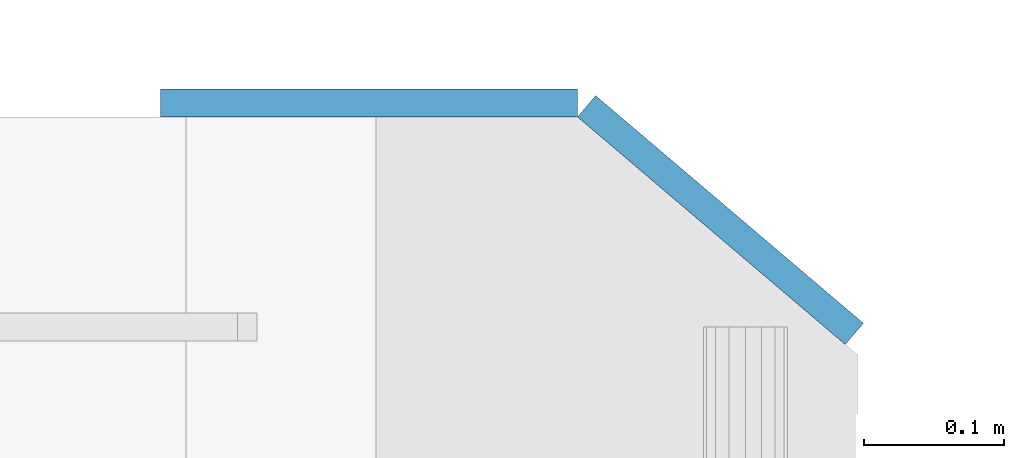
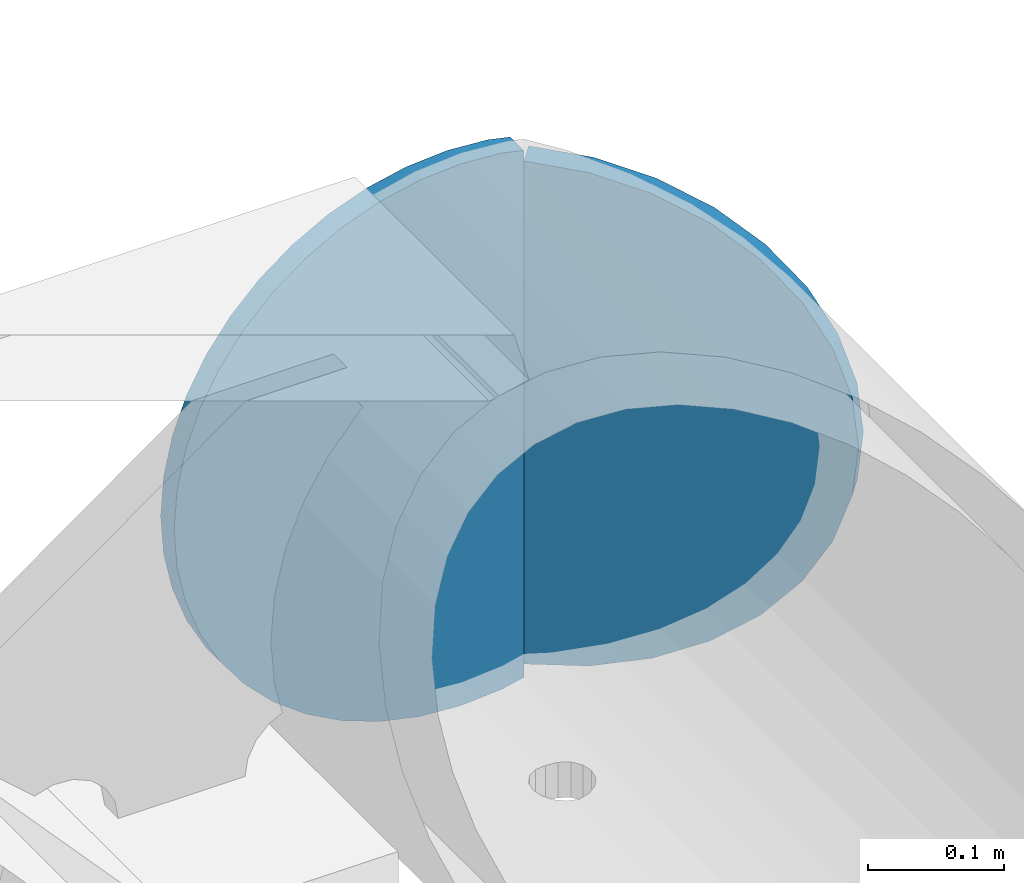
# One storey, part 207 of 219: 2 plates.
"""IFC2X3 building model written with IfcOpenShell, lengths in millimetres."""

from ifc_helpers import new_model, si_unit, frame, origin_with_axes, place, context, subcontext, project, spatial, faceted_brep, material, type_object, element, save


model = new_model("IFC2X3")

# Units and contexts
model_context = context("Model", 3, precision=1e-05, world=origin_with_axes())
body_context = subcontext(model_context, "Body", "Model", "MODEL_VIEW")
ifc_project = project(units=[si_unit("LENGTHUNIT", "METRE", prefix="MILLI"), si_unit("AREAUNIT", "SQUARE_METRE"), si_unit("VOLUMEUNIT", "CUBIC_METRE"), si_unit("MASSUNIT", "GRAM", prefix="KILO"), si_unit("TIMEUNIT", "SECOND"), si_unit("PLANEANGLEUNIT", "RADIAN"), si_unit("SOLIDANGLEUNIT", "STERADIAN"), si_unit("THERMODYNAMICTEMPERATUREUNIT", "DEGREE_CELSIUS"), si_unit("LUMINOUSINTENSITYUNIT", "LUMEN")], contexts=[model_context])

# Site, building, storey
site_placement = place(None, origin_with_axes())
site = spatial("IfcSite", under=ifc_project, at=site_placement, CompositionType="ELEMENT")
building_placement = place(site_placement, origin_with_axes())
building = spatial("IfcBuilding", under=site, at=building_placement, Name="Standard", CompositionType="ELEMENT")
storey_placement = place(building_placement, origin_with_axes())
storey = spatial("IfcBuildingStorey", under=building, at=storey_placement, Name="Undefined", CompositionType="ELEMENT", Elevation=0.0)

# Plates
ifc_material = material(Name="STEEL/S355N")
plate_type_1 = type_object("IfcPlateType", PredefinedType="NOTDEFINED")
plate_1_placement = place(storey_placement, frame((15426.9988298906, 33160.0, -498.000000000001), z_axis=(0.0, 0.0, 1.0), x_axis=(-1.0, 0.0, 0.0)))
element("IfcPlate", 1, at=plate_1_placement, inside=storey, type_object=plate_type_1, material=ifc_material, context=body_context, shape_type="Brep", body=[
    faceted_brep([(244.0, -10.0, 0.0), (209.275179461318, -10.0, 2.48356818105242), (209.275179461318, 10.0, 2.48356818105242), (244.0, 10.0, 0.0), (278.724820538682, -10.0, 2.48356818105236), (278.724820538682, 10.0, 2.48356818105236), (312.742743869308, -10.0, 9.88371443806261), (312.742743869308, 10.0, 9.88371443806261), (345.361263172461, -10.0, 22.0497931334975), (345.361263172461, 10.0, 22.0497931334975), (375.916359459166, -10.0, 38.7341379891918), (375.916359459166, 10.0, 38.7341379891918), (403.78601908265, -10.0, 59.597103857561), (403.78601908265, 10.0, 59.597103857561), (428.402896142439, -10.0, 84.2139809173505), (428.402896142439, 10.0, 84.2139809173505), (449.265862010809, -10.0, 112.083640540834), (449.265862010809, 10.0, 112.083640540834), (465.950206866502, -10.0, 142.63873682754), (465.950206866502, 10.0, 142.63873682754), (478.116285561937, -10.0, 175.257256130691), (478.116285561937, 10.0, 175.257256130691), (485.516431818947, -10.0, 209.275179461318), (485.516431818947, 10.0, 209.275179461318), (488.0, -10.0, 244.0), (488.0, 10.0, 244.0), (485.516431818947, -10.0, 278.724820538682), (485.516431818947, 10.0, 278.724820538682), (478.116285561937, -10.0, 312.742743869309), (478.116285561937, 10.0, 312.742743869309), (465.950206866502, -10.0, 345.36126317246), (465.950206866502, 10.0, 345.36126317246), (449.265862010809, -10.0, 375.916359459166), (449.265862010809, 10.0, 375.916359459166), (428.402896142439, -10.0, 403.78601908265), (428.402896142439, 10.0, 403.78601908265), (403.78601908265, -10.0, 428.402896142439), (403.78601908265, 10.0, 428.402896142439), (375.916359459166, -10.0, 449.265862010808), (375.916359459166, 10.0, 449.265862010808), (345.361263172461, -10.0, 465.950206866503), (345.361263172461, 10.0, 465.950206866503), (312.742743869308, -10.0, 478.116285561937), (312.742743869308, 10.0, 478.116285561937), (278.724820538682, -10.0, 485.516431818948), (278.724820538682, 10.0, 485.516431818948), (244.0, -10.0, 488.0), (244.0, 10.0, 488.0), (209.275179461318, -10.0, 485.516431818948), (209.275179461318, 10.0, 485.516431818948), (190.055415081219, -10.0, 481.335427997648), (190.058547913368, -10.0, 6.6638904964326), (190.053997906718, 10.0, 6.66488028979398), (190.050865087635, 10.0, 481.334438207129)], [[[0, 1, 2, 3]], [[4, 0, 3, 5]], [[6, 4, 5, 7]], [[8, 6, 7, 9]], [[10, 8, 9, 11]], [[12, 10, 11, 13]], [[14, 12, 13, 15]], [[16, 14, 15, 17]], [[18, 16, 17, 19]], [[20, 18, 19, 21]], [[22, 20, 21, 23]], [[24, 22, 23, 25]], [[26, 24, 25, 27]], [[28, 26, 27, 29]], [[30, 28, 29, 31]], [[32, 30, 31, 33]], [[34, 32, 33, 35]], [[36, 34, 35, 37]], [[38, 36, 37, 39]], [[40, 38, 39, 41]], [[42, 40, 41, 43]], [[44, 42, 43, 45]], [[46, 44, 45, 47]], [[48, 46, 47, 49]], [[1, 0, 4, 6, 8, 10, 12, 14, 16, 18, 20, 22, 24, 26, 28, 30, 32, 34, 36, 38, 40, 42, 44, 46, 48, 50, 51]], [[2, 1, 51, 52]], [[49, 47, 45, 43, 41, 39, 37, 35, 33, 31, 29, 27, 25, 23, 21, 19, 17, 15, 13, 11, 9, 7, 5, 3, 2, 52, 53]], [[48, 49, 53, 50]], [[52, 51, 50, 53]]]),
])
plate_type_2 = type_object("IfcPlateType", PredefinedType="NOTDEFINED")
plate_2_placement = place(storey_placement, frame((15280.6680552572, 33125.9531492057, -30.6119535183306), z_axis=(-0.0673151699806089, 0.0572188599835183, -0.996089689713064), x_axis=(-0.758954680570056, 0.64512205263455, 0.0883477789499519)))
element("IfcPlate", 2, at=plate_2_placement, inside=storey, type_object=plate_type_2, material=ifc_material, context=body_context, shape_type="Brep", body=[
    faceted_brep([(0.0, -10.0, 0.0), (-48.0501251221649, -10.0, 8.67006015777554), (-48.0501251221667, 10.0, 8.67006015777577), (0.0, 10.0, 0.0), (-93.1325836184478, -10.0, 25.6772422790526), (-93.1325836184515, 9.99999999999272, 25.6772422790525), (-133.519607544498, -10.0, 50.3672103881837), (-133.519607544502, 10.0, 50.3672103881834), (-167.654617310473, -10.0, 81.7923126220701), (-167.654617310476, 10.0, 81.79231262207), (-194.116653443692, -10.0, 118.75399017334), (-194.116653443691, 10.0, 118.75399017334), (-212.219375612116, -10.0, 159.802307128906), (-212.219375612114, 10.0, 159.802307128906), (-220.935668947557, -10.0, 203.390228271484), (-220.935668947553, 10.0, 203.390228271484), (-220.042388918753, -9.99999999999272, 247.831420898437), (-220.04238891875, 10.0000000000073, 247.831420898438), (-209.448760989544, -10.0000000000073, 291.430206298828), (-209.448760989544, 10.0, 291.430206298828), (-189.931198123782, -9.99999999999272, 332.477691650391), (-189.931198123788, 10.0000000000073, 332.47769165039), (-161.87232971599, -10.0, 369.429595947265), (-161.87232971599, 9.99999999999272, 369.429595947266), (-126.473861698758, -9.99999999999272, 400.854248046875), (-126.473861698762, 10.0, 400.854248046875), (-85.0954742478589, -10.0, 425.544403076172), (-85.0954742478625, 10.0, 425.544403076172), (-39.3266487170386, -10.0, 442.551971435547), (-39.3266487170422, 10.0, 442.551971435547), (9.07161902883126, -10.0000000000073, 451.221954345703), (9.0716190288349, 10.0, 451.221954345703), (49.1691665649414, -10.0, 5.12727638124488e-11), (49.1691665649396, 9.99999999999272, 5.0931703299284e-11)], [[[0, 1, 2, 3]], [[1, 4, 5, 2]], [[4, 6, 7, 5]], [[6, 8, 9, 7]], [[8, 10, 11, 9]], [[10, 12, 13, 11]], [[12, 14, 15, 13]], [[14, 16, 17, 15]], [[16, 18, 19, 17]], [[18, 20, 21, 19]], [[20, 22, 23, 21]], [[22, 24, 25, 23]], [[24, 26, 27, 25]], [[26, 28, 29, 27]], [[28, 30, 31, 29]], [[30, 32, 33, 31]], [[32, 0, 3, 33]], [[5, 7, 9, 11, 13, 15, 17, 19, 21, 23, 25, 27, 29, 31, 33, 3, 2]], [[32, 30, 28, 26, 24, 22, 20, 18, 16, 14, 12, 10, 8, 6, 4, 1, 0]]]),
])

save(model, "model.ifc")
